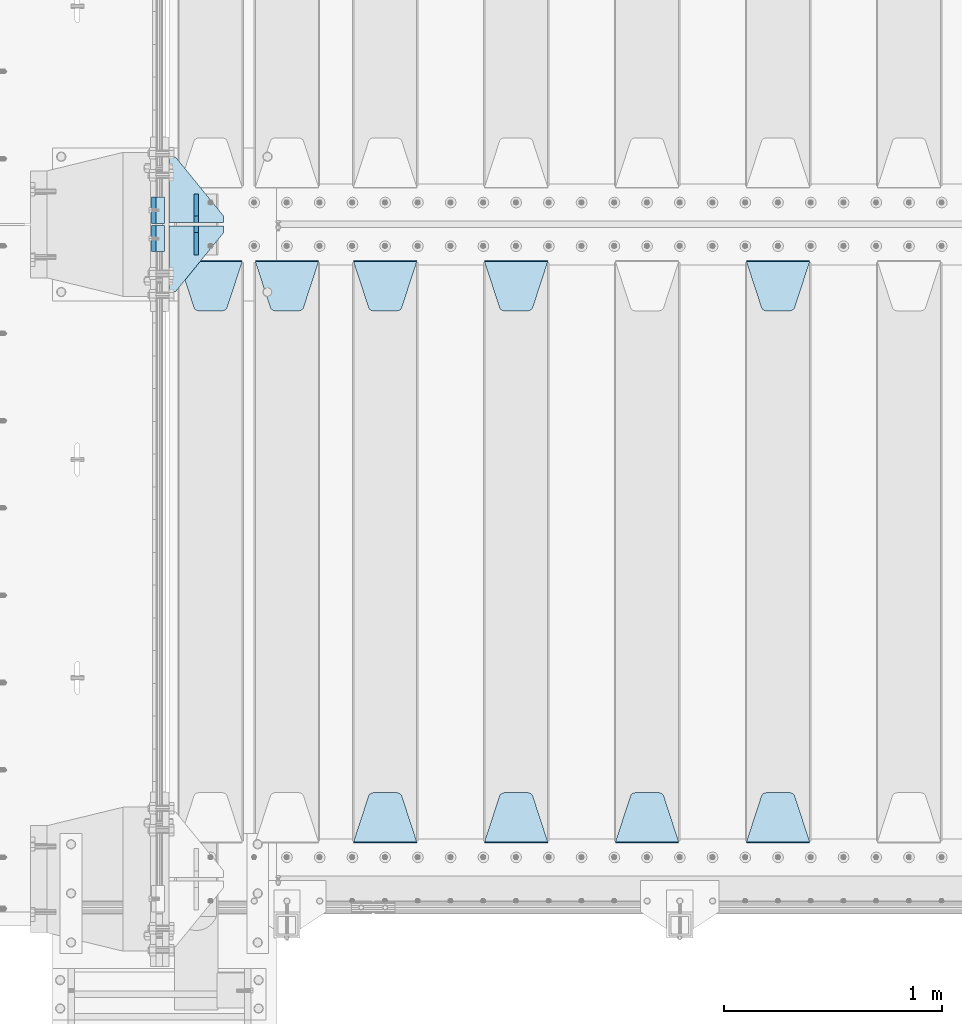
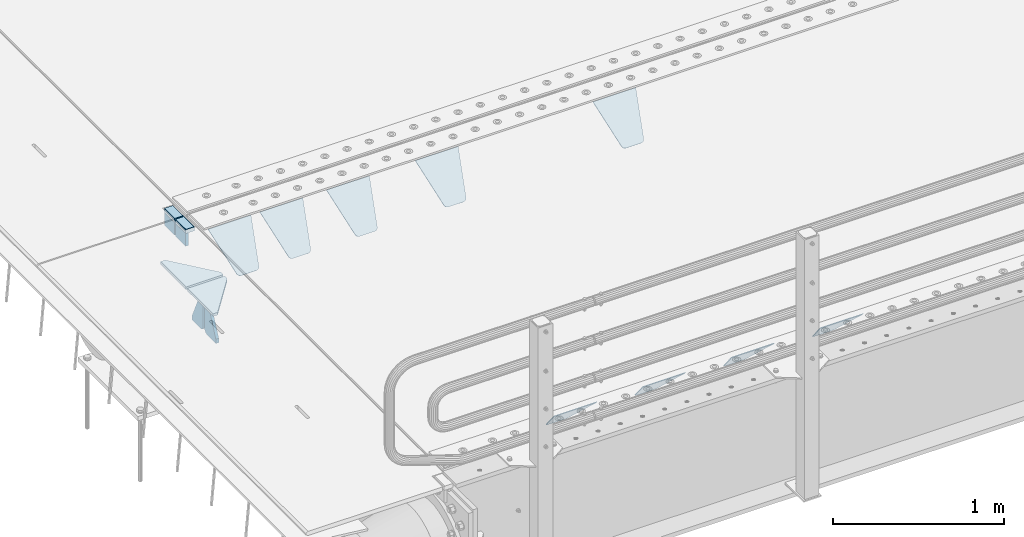
# One storey, part 197 of 247: 17 plates.
"""IFC2X3 building model written with IfcOpenShell, lengths in millimetres."""

from ifc_helpers import new_model, si_unit, frame, origin_with_axes, place, context, subcontext, project, spatial, faceted_brep, material, type_object, element, save


model = new_model("IFC2X3")

# Units and contexts
model_context = context("Model", 3, precision=1e-05, world=origin_with_axes())
body_context = subcontext(model_context, "Body", "Model", "MODEL_VIEW")
ifc_project = project(units=[si_unit("LENGTHUNIT", "METRE", prefix="MILLI"), si_unit("AREAUNIT", "SQUARE_METRE"), si_unit("VOLUMEUNIT", "CUBIC_METRE"), si_unit("MASSUNIT", "GRAM", prefix="KILO"), si_unit("TIMEUNIT", "SECOND"), si_unit("PLANEANGLEUNIT", "RADIAN"), si_unit("SOLIDANGLEUNIT", "STERADIAN"), si_unit("THERMODYNAMICTEMPERATUREUNIT", "DEGREE_CELSIUS"), si_unit("LUMINOUSINTENSITYUNIT", "LUMEN")], contexts=[model_context])

# Site, building, storey
site_placement = place(None, origin_with_axes())
site = spatial("IfcSite", under=ifc_project, at=site_placement, CompositionType="ELEMENT")
building_placement = place(site_placement, origin_with_axes())
building = spatial("IfcBuilding", under=site, at=building_placement, Name="Standard", CompositionType="ELEMENT")
storey_placement = place(building_placement, origin_with_axes())
storey = spatial("IfcBuildingStorey", under=building, at=storey_placement, Name="Undefined", CompositionType="ELEMENT", Elevation=0.0)

# Plates
ifc_material_1 = material()
plate_type_1 = type_object("IfcPlateType", PredefinedType="NOTDEFINED")
plate_1_placement = place(storey_placement, frame((-10.0000000000014, 2935.00000000005, -16.0000945328327), z_axis=(-1.0, 0.0, 0.0), x_axis=(0.0, 0.0, 1.0)))
element("IfcPlate", 1, at=plate_1_placement, inside=storey, type_object=plate_type_1, material=ifc_material_1, context=body_context, shape_type="Brep", body=[
    faceted_brep([(0.0, -59.9999999999991, 0.0), (2.49929144047201e-09, -59.9999999999991, 60.0), (2.49928788775833e-09, 60.0000000000005, 60.0), (-3.5527136788005e-15, 60.0000000000005, 0.0), (25.0146748218828, -59.9999999999991, 60.0), (25.0146748218828, 60.0000000000005, 60.0), (26.5597449794466, -59.9999999999991, 59.7552873949117), (26.5597449794466, 60.0000000000005, 59.7552873949117), (27.9535758796897, -59.9999999999991, 59.0451032832824), (27.9535758796897, 60.0000000000009, 59.0451032832824), (29.0597323263517, -59.9999999999991, 57.9389640667317), (29.0597323263517, 60.0000000000005, 57.9389640667317), (29.7699381491534, -59.9999999999991, 56.5451442289687), (29.7699381491534, 60.0000000000009, 56.5451442289687), (30.0146748212762, -59.9999999999991, 55.0000778834025), (30.0146748212762, 60.0000000000009, 55.0000778834025), (30.0154536553013, -59.9999999999991, 5.00007788340855), (30.0154536553013, 60.0000000000005, 5.00007788340855), (29.7707554908505, -59.9999999999991, 3.45497428546548), (29.7707554908505, 60.0000000000009, 3.45497428546548), (29.0605660948355, -59.9999999999991, 2.06111154407017), (29.0605660948355, 60.0000000000009, 2.06111154407017), (27.9544051209123, -59.9999999999991, 0.954933339696428), (27.9544051209123, 60.0000000000009, 0.954933339696428), (26.5605534420796, -59.9999999999991, 0.244722232012666), (26.5605534420796, 60.0000000000009, 0.244722232012666), (25.0154536559091, -59.9999999999986, 6.05382410867605e-12), (25.0154536559091, 60.0000000000009, 6.05382410867605e-12)], [[[0, 1, 2, 3]], [[1, 4, 5, 2]], [[4, 6, 7, 5]], [[6, 8, 9, 7]], [[8, 10, 11, 9]], [[10, 12, 13, 11]], [[12, 14, 15, 13]], [[14, 16, 17, 15]], [[16, 18, 19, 17]], [[18, 20, 21, 19]], [[20, 22, 23, 21]], [[22, 24, 25, 23]], [[24, 26, 27, 25]], [[26, 0, 3, 27]], [[5, 7, 9, 11, 13, 15, 17, 19, 21, 23, 25, 27, 3, 2]], [[26, 24, 22, 20, 18, 16, 14, 12, 10, 8, 6, 4, 1, 0]]]),
])
plate_2_placement = place(storey_placement, frame((-10.0000000599994, 3065.00000045224, -16.0145962164944), z_axis=(-1.0, 0.0, 0.0), x_axis=(0.0, -4.95099999998473e-06, 0.999999999987744)))
element("IfcPlate", 2, at=plate_2_placement, inside=storey, type_object=plate_type_1, material=ifc_material_1, context=body_context, shape_type="Brep", body=[
    faceted_brep([(0.0, -59.9999999999991, 0.0), (-0.000933120085690575, -60.0, 60.0), (-0.000933120085690575, 60.0, 60.0), (-3.5527136788005e-15, 60.0000000000005, 0.0), (24.9991450303709, -60.0, 60.0), (24.9991450303709, 60.0, 60.0), (26.544215218168, -60.0, 59.7552873850884), (26.544215218168, 60.0, 59.7552873850884), (27.9380461396139, -60.0, 59.0451032459123), (27.9380461396139, 60.0, 59.0451032459123), (29.0442025908961, -60.0, 57.9389639895784), (29.0442025908961, 60.0, 57.9389639895784), (29.7544083969366, -60.0, 56.5451441080361), (29.7544083969366, 60.0, 56.5451441080361), (29.9991450297669, -60.0, 55.0000777244568), (29.9991450297668, 60.0, 55.0000777244568), (29.999922274335, -60.0, 5.00007772445704), (29.999922274335, 60.0, 5.00007772445704), (29.7552240705896, -60.0, 3.45497416452589), (29.7552240705896, 60.0, 3.45497416452589), (29.0450346578116, -60.0, 2.0611114669096), (29.0450346578116, 60.0, 2.06111146690959), (27.9388736885072, -60.0, 0.954933302319514), (27.9388736885072, 60.0, 0.954933302319514), (26.5450220308766, -60.0, 0.244722222183091), (26.5450220308766, 60.0, 0.244722222183089), (24.9999222749392, -60.0, 2.66453525910038e-13), (24.9999222749392, 60.0, 2.66453525910038e-13)], [[[0, 1, 2, 3]], [[1, 4, 5, 2]], [[4, 6, 7, 5]], [[6, 8, 9, 7]], [[8, 10, 11, 9]], [[10, 12, 13, 11]], [[12, 14, 15, 13]], [[14, 16, 17, 15]], [[16, 18, 19, 17]], [[18, 20, 21, 19]], [[20, 22, 23, 21]], [[22, 24, 25, 23]], [[24, 26, 27, 25]], [[26, 0, 3, 27]], [[5, 7, 9, 11, 13, 15, 17, 19, 21, 23, 25, 27, 3, 2]], [[26, 24, 22, 20, 18, 16, 14, 12, 10, 8, 6, 4, 1, 0]]]),
])
ifc_material_2 = material(Name="STEEL/S355N")
plate_type_2 = type_object("IfcPlateType", PredefinedType="NOTDEFINED")
plate_3_placement = place(storey_placement, frame((-60.000000000005, 2995.00008553446, -105.984429072951), z_axis=(0.0, -0.999999999999548, -9.5100000000016e-07), x_axis=(0.0, 0.0, 1.0)))
element("IfcPlate", 3, at=plate_3_placement, inside=storey, type_object=plate_type_2, material=ifc_material_2, context=body_context, shape_type="Brep", body=[
    faceted_brep([(-5.6843418860808e-14, -9.99999999999989, 3.5527136788005e-15), (4.32933688898629e-10, -10.0, 120.0), (4.32933688898629e-10, 10.0, 120.0), (-5.6843418860808e-14, 10.0000000000001, 3.5527136788005e-15), (89.9845046997072, -10.0, 120.0), (89.9845046997072, 10.0, 120.0), (89.9843902587891, -10.0, 6.54836185276508e-11), (89.9843902587891, 10.0, 6.54836185276508e-11)], [[[0, 1, 2, 3]], [[1, 4, 5, 2]], [[4, 6, 7, 5]], [[6, 0, 3, 7]], [[5, 7, 3, 2]], [[6, 4, 1, 0]]]),
])
plate_4_placement = place(storey_placement, frame((-60.0, 3125.00044600192, -106.014921246643), z_axis=(1.00000000012752e-09, -0.999999999987744, -4.95099999993936e-06), x_axis=(0.0, -4.95099999998473e-06, 0.999999999987744)))
element("IfcPlate", 4, at=plate_4_placement, inside=storey, type_object=plate_type_2, material=ifc_material_2, context=body_context, shape_type="Brep", body=[
    faceted_brep([(-5.6843418860808e-14, -9.99999999999989, 3.5527136788005e-15), (4.32933688898629e-10, -10.0, 120.0), (4.32933688898629e-10, 10.0, 120.0), (-5.6843418860808e-14, 10.0000000000001, 3.5527136788005e-15), (90.0, -10.0, 120.0), (90.0, 10.0, 120.0), (90.0, -10.0, 1.09139364212751e-11), (90.0, 10.0, 1.09139364212751e-11)], [[[0, 1, 2, 3]], [[1, 4, 5, 2]], [[4, 6, 7, 5]], [[6, 0, 3, 7]], [[5, 7, 3, 2]], [[6, 4, 1, 0]]]),
])
plate_type_3 = type_object("IfcPlateType", PredefinedType="NOTDEFINED")
plate_5_placement = place(storey_placement, frame((2655.0, 2831.76776695594, -1.767766952965), z_axis=(0.0, -0.707106781186548, -0.707106781186547), x_axis=(1.0, 0.0, 0.0)))
element("IfcPlate", 5, at=plate_5_placement, inside=storey, type_object=plate_type_3, material=ifc_material_2, context=body_context, shape_type="Brep", body=[
    faceted_brep([(0.0, -2.49999999999909, 0.0), (69.345504679477, -2.5, 300.17173142483), (69.345504679477, 2.50000000000091, 300.171731424831), (0.0, 2.5, -9.09494701772928e-13), (70.9274061199576, -2.5, 304.897442415399), (70.9274061199576, 2.50000000000091, 304.8974424154), (73.3818627772307, -2.49999999999909, 309.234538108527), (73.3818627772307, 2.5, 309.234538108526), (76.6187032999551, -2.5, 313.023683126102), (76.6187032999551, 2.50000000000091, 313.023683126102), (80.5190132704993, -2.49999999999909, 316.125672595371), (80.5190132704993, 2.50000000000091, 316.125672595372), (84.9395038596849, -2.49999999999909, 318.426546230476), (84.9395038596849, 2.5, 318.426546230475), (89.7177759439219, -2.5, 319.841774983274), (89.7177759439219, 2.50000000000091, 319.841774983275), (94.678286292652, -2.5, 320.319366455077), (94.678286292652, 2.50000000000091, 320.319366455077), (195.321713707348, -2.5, 320.319366455077), (195.321713707348, 2.50000000000091, 320.319366455077), (200.282224056078, -2.5, 319.841774983274), (200.282224056078, 2.50000000000091, 319.841774983275), (205.060496140315, -2.5, 318.426546230475), (205.060496140315, 2.5, 318.426546230474), (209.480986729501, -2.49999999999818, 316.12567259537), (209.480986729501, 2.50000000000091, 316.12567259537), (213.381296700045, -2.5, 313.023683126101), (213.381296700045, 2.50000000000091, 313.023683126101), (216.618137222769, -2.5, 309.234538108525), (216.618137222769, 2.5, 309.234538108525), (219.072593880042, -2.49999999999909, 304.897442415398), (219.072593880042, 2.5, 304.897442415398), (220.654495320523, -2.5, 300.17173142483), (220.654495320523, 2.50000000000091, 300.171731424831), (290.0, -2.49999999999909, 0.0), (290.0, 2.5, -9.09494701772928e-13)], [[[0, 1, 2, 3]], [[1, 4, 5, 2]], [[4, 6, 7, 5]], [[6, 8, 9, 7]], [[8, 10, 11, 9]], [[10, 12, 13, 11]], [[12, 14, 15, 13]], [[14, 16, 17, 15]], [[16, 18, 19, 17]], [[18, 20, 21, 19]], [[20, 22, 23, 21]], [[22, 24, 25, 23]], [[24, 26, 27, 25]], [[26, 28, 29, 27]], [[28, 30, 31, 29]], [[30, 32, 33, 31]], [[32, 34, 35, 33]], [[34, 0, 3, 35]], [[5, 7, 9, 11, 13, 15, 17, 19, 21, 23, 25, 27, 29, 31, 33, 35, 3, 2]], [[34, 32, 30, 28, 26, 24, 22, 20, 18, 16, 14, 12, 10, 8, 6, 4, 1, 0]]]),
])
plate_6_placement = place(storey_placement, frame((2945.0, 168.232233047034, -1.76776695296758), z_axis=(0.0, 0.707106781186548, -0.707106781186547), x_axis=(-1.0, 0.0, 0.0)))
element("IfcPlate", 6, at=plate_6_placement, inside=storey, type_object=plate_type_3, material=ifc_material_2, context=body_context, shape_type="Brep", body=[
    faceted_brep([(0.0, -2.49999999999909, 0.0), (69.345504679477, -2.5, 300.17173142483), (69.345504679477, 2.50000000000091, 300.171731424831), (0.0, 2.5, -9.09494701772928e-13), (70.9274061199576, -2.5, 304.897442415399), (70.9274061199576, 2.50000000000091, 304.8974424154), (73.3818627772307, -2.49999999999909, 309.234538108527), (73.3818627772307, 2.5, 309.234538108526), (76.6187032999551, -2.5, 313.023683126102), (76.6187032999551, 2.50000000000091, 313.023683126102), (80.5190132704993, -2.49999999999909, 316.125672595371), (80.5190132704993, 2.50000000000091, 316.125672595372), (84.9395038596849, -2.49999999999909, 318.426546230476), (84.9395038596849, 2.5, 318.426546230475), (89.7177759439219, -2.5, 319.841774983274), (89.7177759439219, 2.50000000000091, 319.841774983275), (94.678286292652, -2.5, 320.319366455077), (94.678286292652, 2.50000000000091, 320.319366455077), (195.321713707348, -2.5, 320.319366455077), (195.321713707348, 2.50000000000091, 320.319366455077), (200.282224056078, -2.5, 319.841774983274), (200.282224056078, 2.50000000000091, 319.841774983275), (205.060496140315, -2.5, 318.426546230475), (205.060496140315, 2.5, 318.426546230474), (209.480986729501, -2.49999999999818, 316.12567259537), (209.480986729501, 2.50000000000091, 316.12567259537), (213.381296700045, -2.5, 313.023683126101), (213.381296700045, 2.50000000000091, 313.023683126101), (216.618137222769, -2.5, 309.234538108525), (216.618137222769, 2.5, 309.234538108525), (219.072593880042, -2.49999999999909, 304.897442415398), (219.072593880042, 2.5, 304.897442415398), (220.654495320523, -2.5, 300.17173142483), (220.654495320523, 2.50000000000091, 300.171731424831), (290.0, -2.49999999999909, 0.0), (290.0, 2.5, -9.09494701772928e-13)], [[[0, 1, 2, 3]], [[1, 4, 5, 2]], [[4, 6, 7, 5]], [[6, 8, 9, 7]], [[8, 10, 11, 9]], [[10, 12, 13, 11]], [[12, 14, 15, 13]], [[14, 16, 17, 15]], [[16, 18, 19, 17]], [[18, 20, 21, 19]], [[20, 22, 23, 21]], [[22, 24, 25, 23]], [[24, 26, 27, 25]], [[26, 28, 29, 27]], [[28, 30, 31, 29]], [[30, 32, 33, 31]], [[32, 34, 35, 33]], [[34, 0, 3, 35]], [[5, 7, 9, 11, 13, 15, 17, 19, 21, 23, 25, 27, 29, 31, 33, 35, 3, 2]], [[34, 32, 30, 28, 26, 24, 22, 20, 18, 16, 14, 12, 10, 8, 6, 4, 1, 0]]]),
])
plate_7_placement = place(storey_placement, frame((2345.0, 168.232233047034, -1.76776695296758), z_axis=(0.0, 0.707106781186548, -0.707106781186547), x_axis=(-1.0, 0.0, 0.0)))
element("IfcPlate", 7, at=plate_7_placement, inside=storey, type_object=plate_type_3, material=ifc_material_2, context=body_context, shape_type="Brep", body=[
    faceted_brep([(0.0, -2.49999999999909, 0.0), (69.345504679477, -2.5, 300.17173142483), (69.345504679477, 2.50000000000091, 300.171731424831), (0.0, 2.5, -9.09494701772928e-13), (70.9274061199576, -2.5, 304.897442415399), (70.9274061199576, 2.50000000000091, 304.8974424154), (73.3818627772307, -2.49999999999909, 309.234538108527), (73.3818627772307, 2.5, 309.234538108526), (76.6187032999551, -2.5, 313.023683126102), (76.6187032999551, 2.50000000000091, 313.023683126102), (80.5190132704993, -2.49999999999909, 316.125672595371), (80.5190132704993, 2.50000000000091, 316.125672595372), (84.9395038596849, -2.49999999999909, 318.426546230476), (84.9395038596849, 2.5, 318.426546230475), (89.7177759439219, -2.5, 319.841774983274), (89.7177759439219, 2.50000000000091, 319.841774983275), (94.678286292652, -2.5, 320.319366455077), (94.678286292652, 2.50000000000091, 320.319366455077), (195.321713707348, -2.5, 320.319366455077), (195.321713707348, 2.50000000000091, 320.319366455077), (200.282224056078, -2.5, 319.841774983274), (200.282224056078, 2.50000000000091, 319.841774983275), (205.060496140315, -2.5, 318.426546230475), (205.060496140315, 2.5, 318.426546230474), (209.480986729501, -2.49999999999818, 316.12567259537), (209.480986729501, 2.50000000000091, 316.12567259537), (213.381296700045, -2.5, 313.023683126101), (213.381296700045, 2.50000000000091, 313.023683126101), (216.618137222769, -2.5, 309.234538108525), (216.618137222769, 2.5, 309.234538108525), (219.072593880042, -2.49999999999909, 304.897442415398), (219.072593880042, 2.5, 304.897442415398), (220.654495320523, -2.5, 300.17173142483), (220.654495320523, 2.50000000000091, 300.171731424831), (290.0, -2.49999999999909, 0.0), (290.0, 2.5, -9.09494701772928e-13)], [[[0, 1, 2, 3]], [[1, 4, 5, 2]], [[4, 6, 7, 5]], [[6, 8, 9, 7]], [[8, 10, 11, 9]], [[10, 12, 13, 11]], [[12, 14, 15, 13]], [[14, 16, 17, 15]], [[16, 18, 19, 17]], [[18, 20, 21, 19]], [[20, 22, 23, 21]], [[22, 24, 25, 23]], [[24, 26, 27, 25]], [[26, 28, 29, 27]], [[28, 30, 31, 29]], [[30, 32, 33, 31]], [[32, 34, 35, 33]], [[34, 0, 3, 35]], [[5, 7, 9, 11, 13, 15, 17, 19, 21, 23, 25, 27, 29, 31, 33, 35, 3, 2]], [[34, 32, 30, 28, 26, 24, 22, 20, 18, 16, 14, 12, 10, 8, 6, 4, 1, 0]]]),
])
plate_8_placement = place(storey_placement, frame((1455.0, 2831.76776695594, -1.767766952965), z_axis=(0.0, -0.707106781186548, -0.707106781186547), x_axis=(1.0, 0.0, 0.0)))
element("IfcPlate", 8, at=plate_8_placement, inside=storey, type_object=plate_type_3, material=ifc_material_2, context=body_context, shape_type="Brep", body=[
    faceted_brep([(0.0, -2.49999999999909, 0.0), (69.345504679477, -2.5, 300.17173142483), (69.345504679477, 2.50000000000091, 300.171731424831), (0.0, 2.5, -9.09494701772928e-13), (70.9274061199576, -2.5, 304.897442415399), (70.9274061199576, 2.50000000000091, 304.8974424154), (73.3818627772307, -2.49999999999909, 309.234538108527), (73.3818627772307, 2.5, 309.234538108526), (76.6187032999551, -2.5, 313.023683126102), (76.6187032999551, 2.50000000000091, 313.023683126102), (80.5190132704993, -2.49999999999909, 316.125672595371), (80.5190132704993, 2.50000000000091, 316.125672595372), (84.9395038596849, -2.49999999999909, 318.426546230476), (84.9395038596849, 2.5, 318.426546230475), (89.7177759439219, -2.5, 319.841774983274), (89.7177759439219, 2.50000000000091, 319.841774983275), (94.678286292652, -2.5, 320.319366455077), (94.678286292652, 2.50000000000091, 320.319366455077), (195.321713707348, -2.5, 320.319366455077), (195.321713707348, 2.50000000000091, 320.319366455077), (200.282224056078, -2.5, 319.841774983274), (200.282224056078, 2.50000000000091, 319.841774983275), (205.060496140315, -2.5, 318.426546230475), (205.060496140315, 2.5, 318.426546230474), (209.480986729501, -2.49999999999818, 316.12567259537), (209.480986729501, 2.50000000000091, 316.12567259537), (213.381296700045, -2.5, 313.023683126101), (213.381296700045, 2.50000000000091, 313.023683126101), (216.618137222769, -2.5, 309.234538108525), (216.618137222769, 2.5, 309.234538108525), (219.072593880042, -2.49999999999909, 304.897442415398), (219.072593880042, 2.5, 304.897442415398), (220.654495320523, -2.5, 300.17173142483), (220.654495320523, 2.50000000000091, 300.171731424831), (290.0, -2.49999999999909, 0.0), (290.0, 2.5, -9.09494701772928e-13)], [[[0, 1, 2, 3]], [[1, 4, 5, 2]], [[4, 6, 7, 5]], [[6, 8, 9, 7]], [[8, 10, 11, 9]], [[10, 12, 13, 11]], [[12, 14, 15, 13]], [[14, 16, 17, 15]], [[16, 18, 19, 17]], [[18, 20, 21, 19]], [[20, 22, 23, 21]], [[22, 24, 25, 23]], [[24, 26, 27, 25]], [[26, 28, 29, 27]], [[28, 30, 31, 29]], [[30, 32, 33, 31]], [[32, 34, 35, 33]], [[34, 0, 3, 35]], [[5, 7, 9, 11, 13, 15, 17, 19, 21, 23, 25, 27, 29, 31, 33, 35, 3, 2]], [[34, 32, 30, 28, 26, 24, 22, 20, 18, 16, 14, 12, 10, 8, 6, 4, 1, 0]]]),
])
plate_9_placement = place(storey_placement, frame((1745.0, 168.232233047034, -1.76776695296758), z_axis=(0.0, 0.707106781186548, -0.707106781186547), x_axis=(-1.0, 0.0, 0.0)))
element("IfcPlate", 9, at=plate_9_placement, inside=storey, type_object=plate_type_3, material=ifc_material_2, context=body_context, shape_type="Brep", body=[
    faceted_brep([(0.0, -2.49999999999909, 0.0), (69.345504679477, -2.5, 300.17173142483), (69.345504679477, 2.50000000000091, 300.171731424831), (0.0, 2.5, -9.09494701772928e-13), (70.9274061199576, -2.5, 304.897442415399), (70.9274061199576, 2.50000000000091, 304.8974424154), (73.3818627772307, -2.49999999999909, 309.234538108527), (73.3818627772307, 2.5, 309.234538108526), (76.6187032999551, -2.5, 313.023683126102), (76.6187032999551, 2.50000000000091, 313.023683126102), (80.5190132704993, -2.49999999999909, 316.125672595371), (80.5190132704993, 2.50000000000091, 316.125672595372), (84.9395038596849, -2.49999999999909, 318.426546230476), (84.9395038596849, 2.5, 318.426546230475), (89.7177759439219, -2.5, 319.841774983274), (89.7177759439219, 2.50000000000091, 319.841774983275), (94.678286292652, -2.5, 320.319366455077), (94.678286292652, 2.50000000000091, 320.319366455077), (195.321713707348, -2.5, 320.319366455077), (195.321713707348, 2.50000000000091, 320.319366455077), (200.282224056078, -2.5, 319.841774983274), (200.282224056078, 2.50000000000091, 319.841774983275), (205.060496140315, -2.5, 318.426546230475), (205.060496140315, 2.5, 318.426546230474), (209.480986729501, -2.49999999999818, 316.12567259537), (209.480986729501, 2.50000000000091, 316.12567259537), (213.381296700045, -2.5, 313.023683126101), (213.381296700045, 2.50000000000091, 313.023683126101), (216.618137222769, -2.5, 309.234538108525), (216.618137222769, 2.5, 309.234538108525), (219.072593880042, -2.49999999999909, 304.897442415398), (219.072593880042, 2.5, 304.897442415398), (220.654495320523, -2.5, 300.17173142483), (220.654495320523, 2.50000000000091, 300.171731424831), (290.0, -2.49999999999909, 0.0), (290.0, 2.5, -9.09494701772928e-13)], [[[0, 1, 2, 3]], [[1, 4, 5, 2]], [[4, 6, 7, 5]], [[6, 8, 9, 7]], [[8, 10, 11, 9]], [[10, 12, 13, 11]], [[12, 14, 15, 13]], [[14, 16, 17, 15]], [[16, 18, 19, 17]], [[18, 20, 21, 19]], [[20, 22, 23, 21]], [[22, 24, 25, 23]], [[24, 26, 27, 25]], [[26, 28, 29, 27]], [[28, 30, 31, 29]], [[30, 32, 33, 31]], [[32, 34, 35, 33]], [[34, 0, 3, 35]], [[5, 7, 9, 11, 13, 15, 17, 19, 21, 23, 25, 27, 29, 31, 33, 35, 3, 2]], [[34, 32, 30, 28, 26, 24, 22, 20, 18, 16, 14, 12, 10, 8, 6, 4, 1, 0]]]),
])
plate_10_placement = place(storey_placement, frame((855.0, 2831.76776695594, -1.767766952965), z_axis=(0.0, -0.707106781186548, -0.707106781186547), x_axis=(1.0, 0.0, 0.0)))
element("IfcPlate", 10, at=plate_10_placement, inside=storey, type_object=plate_type_3, material=ifc_material_2, context=body_context, shape_type="Brep", body=[
    faceted_brep([(0.0, -2.49999999999909, 0.0), (69.345504679477, -2.5, 300.17173142483), (69.345504679477, 2.50000000000091, 300.171731424831), (0.0, 2.5, -9.09494701772928e-13), (70.9274061199576, -2.5, 304.897442415399), (70.9274061199576, 2.50000000000091, 304.8974424154), (73.3818627772307, -2.49999999999909, 309.234538108527), (73.3818627772307, 2.5, 309.234538108526), (76.6187032999551, -2.5, 313.023683126102), (76.6187032999551, 2.50000000000091, 313.023683126102), (80.5190132704993, -2.49999999999909, 316.125672595371), (80.5190132704993, 2.50000000000091, 316.125672595372), (84.9395038596849, -2.49999999999909, 318.426546230476), (84.9395038596849, 2.5, 318.426546230475), (89.7177759439219, -2.5, 319.841774983274), (89.7177759439219, 2.50000000000091, 319.841774983275), (94.678286292652, -2.5, 320.319366455077), (94.678286292652, 2.50000000000091, 320.319366455077), (195.321713707348, -2.5, 320.319366455077), (195.321713707348, 2.50000000000091, 320.319366455077), (200.282224056078, -2.5, 319.841774983274), (200.282224056078, 2.50000000000091, 319.841774983275), (205.060496140315, -2.5, 318.426546230475), (205.060496140315, 2.5, 318.426546230474), (209.480986729501, -2.49999999999818, 316.12567259537), (209.480986729501, 2.50000000000091, 316.12567259537), (213.381296700045, -2.5, 313.023683126101), (213.381296700045, 2.50000000000091, 313.023683126101), (216.618137222769, -2.5, 309.234538108525), (216.618137222769, 2.5, 309.234538108525), (219.072593880042, -2.49999999999909, 304.897442415398), (219.072593880042, 2.5, 304.897442415398), (220.654495320523, -2.5, 300.17173142483), (220.654495320523, 2.50000000000091, 300.171731424831), (290.0, -2.49999999999909, 0.0), (290.0, 2.5, -9.09494701772928e-13)], [[[0, 1, 2, 3]], [[1, 4, 5, 2]], [[4, 6, 7, 5]], [[6, 8, 9, 7]], [[8, 10, 11, 9]], [[10, 12, 13, 11]], [[12, 14, 15, 13]], [[14, 16, 17, 15]], [[16, 18, 19, 17]], [[18, 20, 21, 19]], [[20, 22, 23, 21]], [[22, 24, 25, 23]], [[24, 26, 27, 25]], [[26, 28, 29, 27]], [[28, 30, 31, 29]], [[30, 32, 33, 31]], [[32, 34, 35, 33]], [[34, 0, 3, 35]], [[5, 7, 9, 11, 13, 15, 17, 19, 21, 23, 25, 27, 29, 31, 33, 35, 3, 2]], [[34, 32, 30, 28, 26, 24, 22, 20, 18, 16, 14, 12, 10, 8, 6, 4, 1, 0]]]),
])
plate_11_placement = place(storey_placement, frame((1145.0, 168.232233047034, -1.76776695296758), z_axis=(0.0, 0.707106781186548, -0.707106781186547), x_axis=(-1.0, 0.0, 0.0)))
element("IfcPlate", 11, at=plate_11_placement, inside=storey, type_object=plate_type_3, material=ifc_material_2, context=body_context, shape_type="Brep", body=[
    faceted_brep([(0.0, -2.49999999999909, 0.0), (69.345504679477, -2.5, 300.17173142483), (69.345504679477, 2.50000000000091, 300.171731424831), (0.0, 2.5, -9.09494701772928e-13), (70.9274061199576, -2.5, 304.897442415399), (70.9274061199576, 2.50000000000091, 304.8974424154), (73.3818627772307, -2.49999999999909, 309.234538108527), (73.3818627772307, 2.5, 309.234538108526), (76.6187032999551, -2.5, 313.023683126102), (76.6187032999551, 2.50000000000091, 313.023683126102), (80.5190132704993, -2.49999999999909, 316.125672595371), (80.5190132704993, 2.50000000000091, 316.125672595372), (84.9395038596849, -2.49999999999909, 318.426546230476), (84.9395038596849, 2.5, 318.426546230475), (89.7177759439219, -2.5, 319.841774983274), (89.7177759439219, 2.50000000000091, 319.841774983275), (94.678286292652, -2.5, 320.319366455077), (94.678286292652, 2.50000000000091, 320.319366455077), (195.321713707348, -2.5, 320.319366455077), (195.321713707348, 2.50000000000091, 320.319366455077), (200.282224056078, -2.5, 319.841774983274), (200.282224056078, 2.50000000000091, 319.841774983275), (205.060496140315, -2.5, 318.426546230475), (205.060496140315, 2.5, 318.426546230474), (209.480986729501, -2.49999999999818, 316.12567259537), (209.480986729501, 2.50000000000091, 316.12567259537), (213.381296700045, -2.5, 313.023683126101), (213.381296700045, 2.50000000000091, 313.023683126101), (216.618137222769, -2.5, 309.234538108525), (216.618137222769, 2.5, 309.234538108525), (219.072593880042, -2.49999999999909, 304.897442415398), (219.072593880042, 2.5, 304.897442415398), (220.654495320523, -2.5, 300.17173142483), (220.654495320523, 2.50000000000091, 300.171731424831), (290.0, -2.49999999999909, 0.0), (290.0, 2.5, -9.09494701772928e-13)], [[[0, 1, 2, 3]], [[1, 4, 5, 2]], [[4, 6, 7, 5]], [[6, 8, 9, 7]], [[8, 10, 11, 9]], [[10, 12, 13, 11]], [[12, 14, 15, 13]], [[14, 16, 17, 15]], [[16, 18, 19, 17]], [[18, 20, 21, 19]], [[20, 22, 23, 21]], [[22, 24, 25, 23]], [[24, 26, 27, 25]], [[26, 28, 29, 27]], [[28, 30, 31, 29]], [[30, 32, 33, 31]], [[32, 34, 35, 33]], [[34, 0, 3, 35]], [[5, 7, 9, 11, 13, 15, 17, 19, 21, 23, 25, 27, 29, 31, 33, 35, 3, 2]], [[34, 32, 30, 28, 26, 24, 22, 20, 18, 16, 14, 12, 10, 8, 6, 4, 1, 0]]]),
])
plate_12_placement = place(storey_placement, frame((405.0, 2831.76776695594, -1.767766952965), z_axis=(0.0, -0.707106781186548, -0.707106781186547), x_axis=(1.0, 0.0, 0.0)))
element("IfcPlate", 12, at=plate_12_placement, inside=storey, type_object=plate_type_3, material=ifc_material_2, context=body_context, shape_type="Brep", body=[
    faceted_brep([(0.0, -2.49999999999909, 0.0), (69.345504679477, -2.5, 300.17173142483), (69.345504679477, 2.50000000000091, 300.171731424831), (0.0, 2.5, -9.09494701772928e-13), (70.9274061199576, -2.5, 304.897442415399), (70.9274061199576, 2.50000000000091, 304.8974424154), (73.3818627772307, -2.49999999999909, 309.234538108527), (73.3818627772307, 2.5, 309.234538108526), (76.6187032999551, -2.5, 313.023683126102), (76.6187032999551, 2.50000000000091, 313.023683126102), (80.5190132704993, -2.49999999999909, 316.125672595371), (80.5190132704993, 2.50000000000091, 316.125672595372), (84.9395038596849, -2.49999999999909, 318.426546230476), (84.9395038596849, 2.5, 318.426546230475), (89.7177759439219, -2.5, 319.841774983274), (89.7177759439219, 2.50000000000091, 319.841774983275), (94.678286292652, -2.5, 320.319366455077), (94.678286292652, 2.50000000000091, 320.319366455077), (195.321713707348, -2.5, 320.319366455077), (195.321713707348, 2.50000000000091, 320.319366455077), (200.282224056078, -2.5, 319.841774983274), (200.282224056078, 2.50000000000091, 319.841774983275), (205.060496140315, -2.5, 318.426546230475), (205.060496140315, 2.5, 318.426546230474), (209.480986729501, -2.49999999999818, 316.12567259537), (209.480986729501, 2.50000000000091, 316.12567259537), (213.381296700045, -2.5, 313.023683126101), (213.381296700045, 2.50000000000091, 313.023683126101), (216.618137222769, -2.5, 309.234538108525), (216.618137222769, 2.5, 309.234538108525), (219.072593880042, -2.49999999999909, 304.897442415398), (219.072593880042, 2.5, 304.897442415398), (220.654495320523, -2.5, 300.17173142483), (220.654495320523, 2.50000000000091, 300.171731424831), (290.0, -2.49999999999909, 0.0), (290.0, 2.5, -9.09494701772928e-13)], [[[0, 1, 2, 3]], [[1, 4, 5, 2]], [[4, 6, 7, 5]], [[6, 8, 9, 7]], [[8, 10, 11, 9]], [[10, 12, 13, 11]], [[12, 14, 15, 13]], [[14, 16, 17, 15]], [[16, 18, 19, 17]], [[18, 20, 21, 19]], [[20, 22, 23, 21]], [[22, 24, 25, 23]], [[24, 26, 27, 25]], [[26, 28, 29, 27]], [[28, 30, 31, 29]], [[30, 32, 33, 31]], [[32, 34, 35, 33]], [[34, 0, 3, 35]], [[5, 7, 9, 11, 13, 15, 17, 19, 21, 23, 25, 27, 29, 31, 33, 35, 3, 2]], [[34, 32, 30, 28, 26, 24, 22, 20, 18, 16, 14, 12, 10, 8, 6, 4, 1, 0]]]),
])
plate_13_placement = place(storey_placement, frame((55.0, 2831.76776695594, -1.767766952965), z_axis=(0.0, -0.707106781186548, -0.707106781186547), x_axis=(1.0, 0.0, 0.0)))
element("IfcPlate", 13, at=plate_13_placement, inside=storey, type_object=plate_type_3, material=ifc_material_2, context=body_context, shape_type="Brep", body=[
    faceted_brep([(0.0, -2.49999999999909, 0.0), (69.345504679477, -2.5, 300.17173142483), (69.345504679477, 2.50000000000091, 300.171731424831), (0.0, 2.5, -9.09494701772928e-13), (70.9274061199576, -2.5, 304.897442415399), (70.9274061199576, 2.50000000000091, 304.8974424154), (73.3818627772307, -2.49999999999909, 309.234538108527), (73.3818627772307, 2.5, 309.234538108526), (76.6187032999551, -2.5, 313.023683126102), (76.6187032999551, 2.50000000000091, 313.023683126102), (80.5190132704993, -2.49999999999909, 316.125672595371), (80.5190132704993, 2.50000000000091, 316.125672595372), (84.9395038596849, -2.49999999999909, 318.426546230476), (84.9395038596849, 2.5, 318.426546230475), (89.7177759439219, -2.5, 319.841774983274), (89.7177759439219, 2.50000000000091, 319.841774983275), (94.678286292652, -2.5, 320.319366455077), (94.678286292652, 2.50000000000091, 320.319366455077), (195.321713707348, -2.5, 320.319366455077), (195.321713707348, 2.50000000000091, 320.319366455077), (200.282224056078, -2.5, 319.841774983274), (200.282224056078, 2.50000000000091, 319.841774983275), (205.060496140315, -2.5, 318.426546230475), (205.060496140315, 2.5, 318.426546230474), (209.480986729501, -2.49999999999818, 316.12567259537), (209.480986729501, 2.50000000000091, 316.12567259537), (213.381296700045, -2.5, 313.023683126101), (213.381296700045, 2.50000000000091, 313.023683126101), (216.618137222769, -2.5, 309.234538108525), (216.618137222769, 2.5, 309.234538108525), (219.072593880042, -2.49999999999909, 304.897442415398), (219.072593880042, 2.5, 304.897442415398), (220.654495320523, -2.5, 300.17173142483), (220.654495320523, 2.50000000000091, 300.171731424831), (290.0, -2.49999999999909, 0.0), (290.0, 2.5, -9.09494701772928e-13)], [[[0, 1, 2, 3]], [[1, 4, 5, 2]], [[4, 6, 7, 5]], [[6, 8, 9, 7]], [[8, 10, 11, 9]], [[10, 12, 13, 11]], [[12, 14, 15, 13]], [[14, 16, 17, 15]], [[16, 18, 19, 17]], [[18, 20, 21, 19]], [[20, 22, 23, 21]], [[22, 24, 25, 23]], [[24, 26, 27, 25]], [[26, 28, 29, 27]], [[28, 30, 31, 29]], [[30, 32, 33, 31]], [[32, 34, 35, 33]], [[34, 0, 3, 35]], [[5, 7, 9, 11, 13, 15, 17, 19, 21, 23, 25, 27, 29, 31, 33, 35, 3, 2]], [[34, 32, 30, 28, 26, 24, 22, 20, 18, 16, 14, 12, 10, 8, 6, 4, 1, 0]]]),
])
plate_type_4 = type_object("IfcPlateType", PredefinedType="NOTDEFINED")
for number, where, z_axis, x_axis in (
    (14, (259.999999999996, 3008.0, -515.0), (0.0, 1.0, 0.0), (-1.0, 0.0, 0.0)),
    (15, (259.999999999996, 2992.0, -515.0), (0.0, -0.999999999999548, -9.5100000000016e-07), (-1.0, 0.0, 0.0)),
):
    element("IfcPlate", number, at=place(storey_placement, frame(where, z_axis=z_axis, x_axis=x_axis)), inside=storey, type_object=plate_type_4, material=ifc_material_2, context=body_context, shape_type="Brep", body=[
        faceted_brep([(-5.6843418860808e-14, -9.99999999999989, 3.5527136788005e-15), (0.0, -10.0, 30.0), (0.0, 10.0, 30.0), (-5.6843418860808e-14, 10.0000000000001, 3.5527136788005e-15), (220.0, -10.0, 300.0), (220.0, 10.0, 300.0), (250.0, -10.0, 300.0), (250.0, 10.0, 300.0), (250.0, -10.0, 0.0), (250.0, 10.0, 0.0)], [[[0, 1, 2, 3]], [[1, 4, 5, 2]], [[4, 6, 7, 5]], [[6, 8, 9, 7]], [[8, 0, 3, 9]], [[5, 7, 9, 3, 2]], [[8, 6, 4, 1, 0]]]),
    ])
plate_type_5 = type_object("IfcPlateType", PredefinedType="NOTDEFINED")
for number, where, z_axis, x_axis in (
    (16, (135.0, 3140.0, -860.0), (0.0, 0.0, 1.0), (0.0, -0.999999999999548, -9.5100000000016e-07)),
    (17, (135.0, 2860.0, -860.0), (0.0, 0.0, 1.0), (0.0, 1.0, 0.0)),
):
    element("IfcPlate", number, at=place(storey_placement, frame(where, z_axis=z_axis, x_axis=x_axis)), inside=storey, type_object=plate_type_5, material=ifc_material_2, context=body_context, shape_type="Brep", body=[
        faceted_brep([(-5.6843418860808e-14, -9.99999999999989, 3.5527136788005e-15), (0.0, -10.0, 30.0), (0.0, 10.0, 30.0), (-5.6843418860808e-14, 10.0000000000001, 3.5527136788005e-15), (102.0, -10.0, 250.0), (102.0, 10.0, 250.0), (132.0, -10.0, 250.0), (132.0, 10.0, 250.0), (132.0, -10.0, 30.0), (132.0, 10.0, 30.0), (131.544232590366, -10.0, 24.790554669992), (131.544232590366, 10.0, 24.790554669992), (130.190778623577, -10.0, 19.7393957002299), (130.190778623577, 10.0, 19.7393957002299), (127.980762113533, -10.0, 15.0), (127.980762113533, 10.0, 15.0), (124.981333293569, -10.0, 10.7163717094038), (124.981333293569, 10.0, 10.7163717094038), (121.283628290596, -10.0, 7.01866670643062), (121.283628290596, 10.0, 7.01866670643062), (117.0, -10.0, 4.01923788646684), (117.0, 10.0, 4.01923788646684), (112.26060429977, -10.0, 1.80922137642278), (112.26060429977, 10.0, 1.80922137642278), (107.209445330008, -10.0, 0.455767409633722), (107.209445330008, 10.0, 0.455767409633722), (102.0, -10.0, 0.0), (102.0, 10.0, 0.0)], [[[0, 1, 2, 3]], [[1, 4, 5, 2]], [[4, 6, 7, 5]], [[6, 8, 9, 7]], [[8, 10, 11, 9]], [[10, 12, 13, 11]], [[12, 14, 15, 13]], [[14, 16, 17, 15]], [[16, 18, 19, 17]], [[18, 20, 21, 19]], [[20, 22, 23, 21]], [[22, 24, 25, 23]], [[24, 26, 27, 25]], [[26, 0, 3, 27]], [[5, 7, 9, 11, 13, 15, 17, 19, 21, 23, 25, 27, 3, 2]], [[26, 24, 22, 20, 18, 16, 14, 12, 10, 8, 6, 4, 1, 0]]]),
    ])

save(model, "model.ifc")
